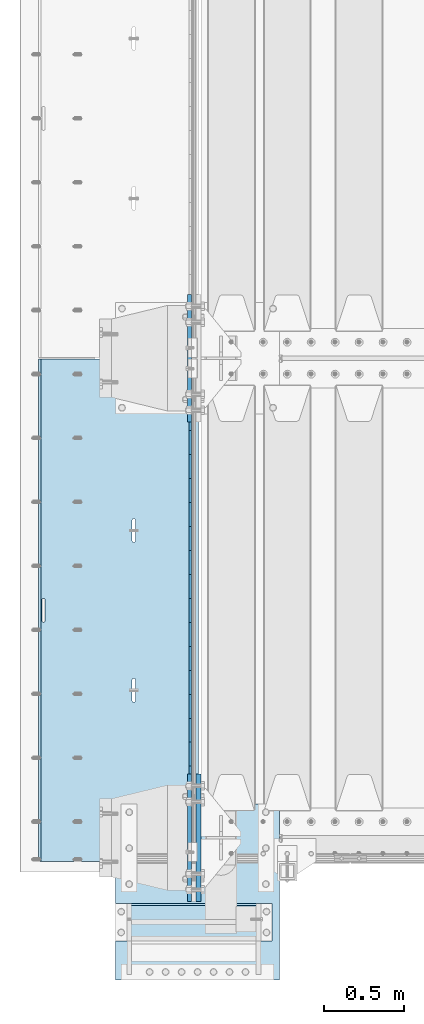
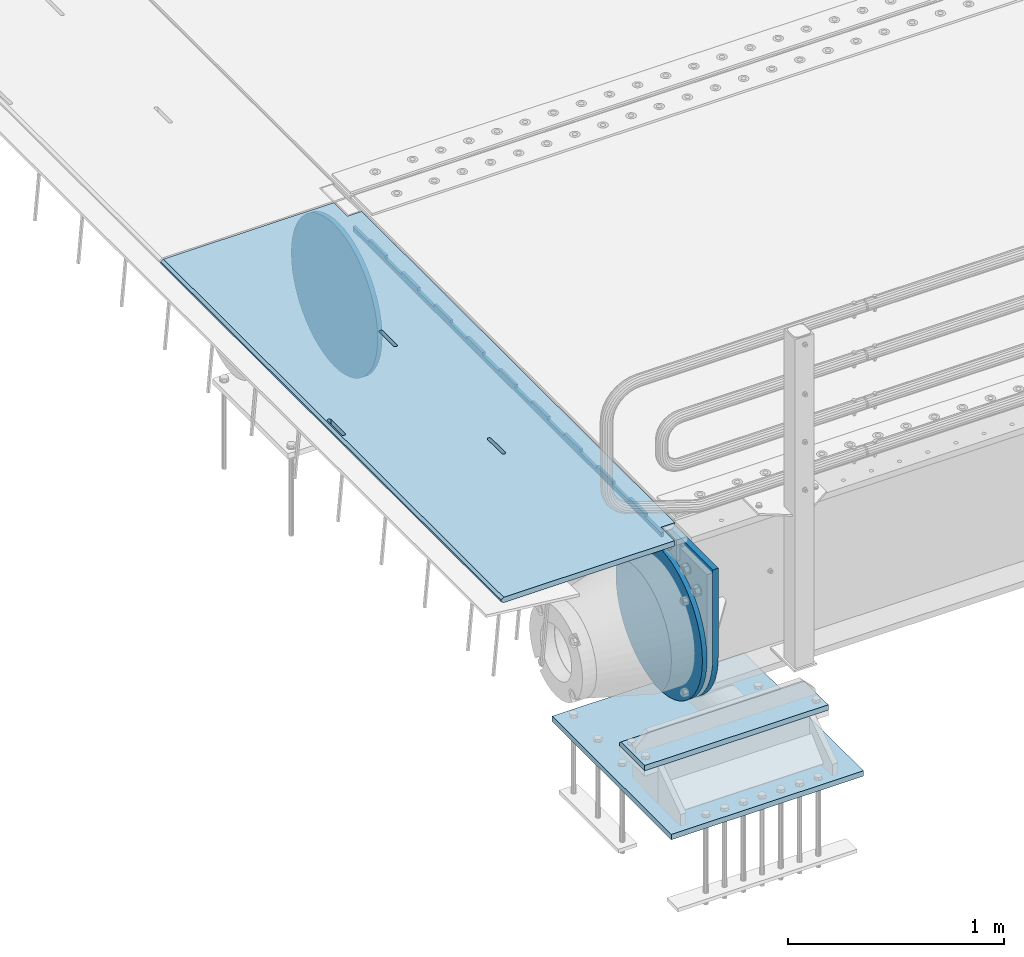
# One storey, part 208 of 270: 7 plates.
"""IFC2X3 building model written with IfcOpenShell, lengths in millimetres."""

import ifcopenshell
import ifcopenshell.guid

model = None  # the IFC model being written
_history = None  # IfcOwnerHistory: only IFC2X3 demands one
_inside = {}  # id of a spatial element -> (the spatial element, [elements in it])
_under = {}  # id of a project, library or spatial element -> (it, [spatial elements below it])
_declared = {}  # id of a project -> (the project, [libraries it declares])
_typed = {}  # id of a type object -> (the type object, [elements of that type])
_made_of = {}  # id of a material, layer set ... -> (it, [elements and type objects made of it])


def new_model(schema):
    """Start an empty IFC model of exactly this schema.

    Asked for "IFC4X3", IfcOpenShell would pick the latest addendum, in which some entities
    have other attributes; the version numbers below select the first issue.
    IFC2X3 requires an IfcOwnerHistory on every rooted entity: one is made here for all.
    """
    global model, _history
    if schema == "IFC4X3":
        model = ifcopenshell.file(schema_version=(4, 3, 0, 0))
    else:
        model = ifcopenshell.file(schema=schema)
    _inside.clear()
    _under.clear()
    _declared.clear()
    _typed.clear()
    _made_of.clear()
    _history = None
    if model.schema == "IFC2X3":
        org = make("IfcOrganization", Name="unknown")
        user = make(
            "IfcPersonAndOrganization",
            ThePerson=make("IfcPerson", FamilyName="unknown"),
            TheOrganization=org,
        )
        app = make(
            "IfcApplication",
            ApplicationDeveloper=org,
            Version="unknown",
            ApplicationFullName="unknown",
            ApplicationIdentifier="unknown",
        )
        _history = make(
            "IfcOwnerHistory",
            OwningUser=user,
            OwningApplication=app,
            ChangeAction="ADDED",
            CreationDate=0,
        )
    return model


def make(cls, **values):
    """One entity of the class cls with the attributes given. An attribute that is None is left unset."""
    return model.create_entity(
        cls, **{name: value for name, value in values.items() if value is not None}
    )


def rooted(cls, **values):
    """An entity with a GlobalId (a new one), such as an element, a storey or a relation."""
    return make(cls, GlobalId=ifcopenshell.guid.new(), OwnerHistory=_history, **values)


def si_unit(unit_type, name, prefix=None):
    """IfcSIUnit, for example si_unit("LENGTHUNIT", "METRE", prefix="MILLI")."""
    return make("IfcSIUnit", UnitType=unit_type, Prefix=prefix, Name=name)


def assignment(units):
    """IfcUnitAssignment: the units of a project."""
    return None if units is None else make("IfcUnitAssignment", Units=units)


def point(xyz):
    """IfcCartesianPoint."""
    return None if xyz is None else make("IfcCartesianPoint", Coordinates=xyz)


def direction(xyz):
    """IfcDirection."""
    return None if xyz is None else make("IfcDirection", DirectionRatios=xyz)


def frame(location, z_axis=None, x_axis=None):
    """IfcAxis2Placement3D, a coordinate frame: its origin and axes. An axis left out is left unset."""
    return make(
        "IfcAxis2Placement3D",
        Location=point(location),
        Axis=direction(z_axis),
        RefDirection=direction(x_axis),
    )


def origin_with_axes():
    """The frame at (0, 0, 0) with the z axis (0, 0, 1) and the x axis (1, 0, 0) written out."""
    return frame((0.0, 0.0, 0.0), z_axis=(0.0, 0.0, 1.0), x_axis=(1.0, 0.0, 0.0))


def place(relative_to, where):
    """IfcLocalPlacement: puts the frame where relative to a parent placement (None: the world)."""
    return make(
        "IfcLocalPlacement", PlacementRelTo=relative_to, RelativePlacement=where
    )


def context(
    kind, dimensions, precision=None, world=None, true_north=None, identifier=None
):
    """IfcGeometricRepresentationContext, for example the 3D "Model" context."""
    return make(
        "IfcGeometricRepresentationContext",
        ContextIdentifier=identifier,
        ContextType=kind,
        CoordinateSpaceDimension=dimensions,
        Precision=precision,
        WorldCoordinateSystem=world,
        TrueNorth=true_north,
    )


def subcontext(parent, identifier, kind, view, scale=None):
    """IfcGeometricRepresentationSubContext, for example "Body" below "Model"."""
    return make(
        "IfcGeometricRepresentationSubContext",
        ContextIdentifier=identifier,
        ContextType=kind,
        ParentContext=parent,
        TargetScale=scale,
        TargetView=view,
    )


def project(units=None, contexts=None):
    """IfcProject with its units and contexts."""
    return rooted(
        "IfcProject",
        Name="project",
        RepresentationContexts=contexts,
        UnitsInContext=assignment(units),
    )


def spatial(cls, under=None, at=None, **own):
    """A site, building, storey or space (cls), placed at a placement, below another one or the project."""
    s = rooted(cls, ObjectPlacement=at, **own)
    if under is not None:
        _under.setdefault(under.id(), (under, []))[1].append(s)
    return s


def faces_of(points, faces, orient=None, outer=None):
    """IfcFace entities. A face is a list of loops; a loop is a list of indices into points, from 0.

    orient and outer hold one flag for each loop. By default every Orientation is true, the
    first loop of a face is its IfcFaceOuterBound and the others are IfcFaceBound.
    """
    made = []
    for i, loops in enumerate(faces):
        bounds = []
        for j, loop in enumerate(loops):
            is_outer = j == 0 if outer is None else outer[i][j]
            bounds.append(
                make(
                    "IfcFaceOuterBound" if is_outer else "IfcFaceBound",
                    Bound=make("IfcPolyLoop", Polygon=[points[k] for k in loop]),
                    Orientation=True if orient is None else orient[i][j],
                )
            )
        made.append(make("IfcFace", Bounds=bounds))
    return made


def faceted_brep(points, faces, orient=None, outer=None, voids=None):
    """IfcFacetedBrep: a solid bounded by flat faces; with voids (closed shells), ...WithVoids."""
    shared = [point(p) for p in points]
    hull = make("IfcClosedShell", CfsFaces=faces_of(shared, faces, orient, outer))
    if voids is None:
        return make("IfcFacetedBrep", Outer=hull)
    return make(
        "IfcFacetedBrepWithVoids",
        Outer=hull,
        Voids=[
            make(cls, CfsFaces=faces_of(shared, fs, o, b)) for cls, fs, o, b in voids
        ],
    )


def shape(context_of_items, identifier, shape_type, items):
    """IfcShapeRepresentation: the items that make up one representation, for example the "Body"."""
    return make(
        "IfcShapeRepresentation",
        ContextOfItems=context_of_items,
        RepresentationIdentifier=identifier,
        RepresentationType=shape_type,
        Items=items,
    )


def material(Name=None, Category=None):
    """IfcMaterial."""
    return make("IfcMaterial", Name=Name, Category=Category)


def made_of(thing, what):
    """Note that an element or type object is made of a material, layer set ...; save() writes the relation."""
    if what is not None:
        _made_of.setdefault(what.id(), (what, []))[1].append(thing)
    return thing


def type_object(cls, material=None, **own):
    """A type object (cls), such as IfcWallType, which elements share."""
    return made_of(rooted(cls, **own), material)


def element(
    cls,
    number,
    at=None,
    inside=None,
    cuts=None,
    type_object=None,
    material=None,
    context=None,
    identifier="Body",
    shape_type=None,
    held_by="IfcProductDefinitionShape",
    body=None,
    shapes=None,
    **own,
):
    """One element of the class cls, such as IfcWall. Its Tag is "e" and its number.

    at: its placement. inside: the storey or other place that contains it. cuts: it is an
    opening in that element (IfcRelVoidsElement). A single representation is given by context,
    identifier, shape_type and body (its items); several are given by shapes. held_by: the class
    of the entity that holds the representations. save() writes the other relations.
    """
    e = rooted(cls, Tag="e%d" % number, ObjectPlacement=at, **own)
    if body is not None:
        shapes = [shape(context, identifier, shape_type, body)]
    if shapes is not None:
        e.Representation = make(held_by, Representations=shapes)
    if inside is not None:
        _inside.setdefault(inside.id(), (inside, []))[1].append(e)
    if cuts is not None:
        rooted(
            "IfcRelVoidsElement", RelatingBuildingElement=cuts, RelatedOpeningElement=e
        )
    if type_object is not None:
        _typed.setdefault(type_object.id(), (type_object, []))[1].append(e)
    return made_of(e, material)


def aggregate(whole, parts):
    """IfcRelAggregates: a whole, such as a stair, and the parts it consists of."""
    return rooted("IfcRelAggregates", RelatingObject=whole, RelatedObjects=parts)


def save(model, path):
    """Write the relations noted so far, then the file.

    IfcRelAggregates (storeys below a building ...), IfcRelContainedInSpatialStructure (elements
    in a storey), IfcRelDefinesByType, IfcRelAssociatesMaterial and IfcRelDeclares: one each for
    every whole, place, type object, material and project.
    """
    for whole, parts in _under.values():
        aggregate(whole, parts)
    for where, things in _inside.values():
        rooted(
            "IfcRelContainedInSpatialStructure",
            RelatedElements=things,
            RelatingStructure=where,
        )
    for kind, things in _typed.values():
        rooted("IfcRelDefinesByType", RelatedObjects=things, RelatingType=kind)
    for what, things in _made_of.values():
        rooted("IfcRelAssociatesMaterial", RelatedObjects=things, RelatingMaterial=what)
    for by, libraries in _declared.values():
        rooted("IfcRelDeclares", RelatingContext=by, RelatedDefinitions=libraries)
    model.write(path)


model = new_model("IFC2X3")

# Units and contexts
model_context = context("Model", 3, precision=1e-05, world=origin_with_axes())
body_context = subcontext(model_context, "Body", "Model", "MODEL_VIEW")
ifc_project = project(units=[si_unit("LENGTHUNIT", "METRE", prefix="MILLI"), si_unit("AREAUNIT", "SQUARE_METRE"), si_unit("VOLUMEUNIT", "CUBIC_METRE"), si_unit("MASSUNIT", "GRAM", prefix="KILO"), si_unit("TIMEUNIT", "SECOND"), si_unit("PLANEANGLEUNIT", "RADIAN"), si_unit("SOLIDANGLEUNIT", "STERADIAN"), si_unit("THERMODYNAMICTEMPERATUREUNIT", "DEGREE_CELSIUS"), si_unit("LUMINOUSINTENSITYUNIT", "LUMEN")], contexts=[model_context])

# Site, building, storey
site_placement = place(None, origin_with_axes())
site = spatial("IfcSite", under=ifc_project, at=site_placement, CompositionType="ELEMENT")
building_placement = place(site_placement, origin_with_axes())
building = spatial("IfcBuilding", under=site, at=building_placement, Name="Standard", CompositionType="ELEMENT")
storey_placement = place(building_placement, origin_with_axes())
storey = spatial("IfcBuildingStorey", under=building, at=storey_placement, Name="Undefined", CompositionType="ELEMENT", Elevation=0.0)

# Plates
ifc_material_1 = material(Name="STEEL/S355N")
plate_type_1 = type_object("IfcPlateType", PredefinedType="NOTDEFINED")
plate_1_placement = place(storey_placement, frame((-57.5000000000039, -21152.4999006275, -35.9858217365063), z_axis=(0.0, -0.999999999987744, -4.95099999993769e-06), x_axis=(0.0, 4.95100000930963e-06, -0.999999999987744)))
element("IfcPlate", 1, at=plate_1_placement, inside=storey, type_object=plate_type_1, material=ifc_material_1, context=body_context, shape_type="Brep", body=[
    faceted_brep([(-7.105427357601e-15, -7.49999999999999, 0.0), (8.68283223098842e-12, -7.49999999999999, 150.000000000004), (8.68283223098842e-12, 7.5, 150.000000000004), (-7.105427357601e-15, 7.5, 0.0), (-14.9999999999986, -7.49999999999999, 150.0), (-14.9999999999986, 7.5, 150.0), (-14.9999999999972, -7.49999999999999, 300.0), (-14.9999999999972, 7.5, 300.0), (1.55324642037158e-11, -7.49999999999999, 300.0), (1.55324642037158e-11, 7.5, 300.0), (1.87654336514242e-11, -7.49999999999999, 450.0), (1.87654336514242e-11, 7.5, 450.0), (-14.9999999999958, -7.49999999999999, 450.0), (-14.9999999999958, 7.5, 450.0), (-14.9999999999944, -7.49999999999999, 600.0), (-14.9999999999944, 7.5, 600.0), (2.74411604550551e-11, -7.49999999999999, 600.000000000004), (2.74411604550551e-11, 7.5, 600.000000000004), (3.24860138789518e-11, -7.49999999999999, 750.0), (3.24860138789518e-11, 7.5, 750.0), (-14.999999999993, -7.49999999999999, 750.0), (-14.999999999993, 7.5, 750.0), (-14.9999999999916, -7.49999999999999, 900.000000000004), (-14.9999999999916, 7.5, 900.000000000004), (4.11688461099402e-11, -7.49999999999999, 900.0), (4.11688461099402e-11, 7.5, 900.0), (4.62136995338369e-11, -7.49999999999999, 1050.0), (4.62136995338369e-11, 7.5, 1050.0), (-14.9999999999902, -7.49999999999999, 1050.0), (-14.9999999999902, 7.5, 1050.0), (-14.9999999999888, -7.49999999999999, 1200.0), (-14.9999999999888, 7.5, 1200.0), (5.30775423612795e-11, -7.49999999999999, 1200.0), (5.30775423612795e-11, 7.5, 1200.0), (5.99413851887221e-11, -7.49999999999999, 1350.0), (5.99413851887221e-11, 7.5, 1350.0), (-14.9999999999874, -7.49999999999999, 1350.0), (-14.9999999999874, 7.5, 1350.0), (-14.9999999999859, -7.49999999999999, 1500.0), (-14.9999999999859, 7.5, 1500.0), (6.49862386126188e-11, -7.49999999999999, 1500.0), (6.49862386126188e-11, 7.5, 1500.0), (7.36690708436072e-11, -7.49999999999999, 1650.0), (7.36690708436072e-11, 7.5, 1650.0), (-14.9999999999845, -7.49999999999999, 1650.0), (-14.9999999999845, 7.5, 1650.0), (-14.9999999999831, -7.49999999999999, 1800.0), (-14.9999999999831, 7.5, 1800.0), (7.68878294366004e-11, -7.49999999999999, 1800.0), (7.68878294366004e-11, 7.5, 1800.0), (8.3751672264043e-11, -7.49999999999999, 1950.0), (8.3751672264043e-11, 7.5, 1950.0), (-14.9999999999817, -7.49999999999999, 1950.0), (-14.9999999999817, 7.5, 1950.0), (-14.9999999999803, -7.49999999999999, 2100.0), (-14.9999999999803, 7.5, 2100.0), (9.06226205188432e-11, -7.49999999999999, 2100.0), (9.06226205188432e-11, 7.5, 2100.0), (9.56603685153823e-11, -7.49999999999999, 2250.0), (9.56603685153823e-11, 7.5, 2250.0), (-14.9999999999789, -7.49999999999999, 2250.0), (-14.9999999999789, 7.5, 2250.0), (-14.9999999999775, -7.49999999999999, 2400.0), (-14.9999999999775, 7.5, 2400.0), (1.04343200746371e-10, -7.49999999999999, 2400.0), (1.04343200746371e-10, 7.5, 2400.0), (1.0938094874291e-10, -7.49999999999999, 2550.0), (1.0938094874291e-10, 7.5, 2550.0), (-14.9999999999761, -7.49999999999999, 2550.0), (-14.9999999999761, 7.5, 2550.0), (-14.9999999999747, -7.49999999999999, 2700.0), (-14.9999999999747, 7.5, 2700.0), (1.14432907594164e-10, -7.49999999999999, 2700.0), (1.14432907594164e-10, 7.5, 2700.0), (1.23108634397795e-10, -7.49999999999999, 2850.0), (1.23108634397795e-10, 7.5, 2850.0), (25.0000000000267, -7.49999999999999, 2850.0), (25.0000000000267, 7.5, 2850.0), (25.0, -7.49999999999999, 0.0), (25.0, 7.5, 0.0)], [[[0, 1, 2, 3]], [[1, 4, 5, 2]], [[4, 6, 7, 5]], [[6, 8, 9, 7]], [[8, 10, 11, 9]], [[10, 12, 13, 11]], [[12, 14, 15, 13]], [[14, 16, 17, 15]], [[16, 18, 19, 17]], [[18, 20, 21, 19]], [[20, 22, 23, 21]], [[22, 24, 25, 23]], [[24, 26, 27, 25]], [[26, 28, 29, 27]], [[28, 30, 31, 29]], [[30, 32, 33, 31]], [[32, 34, 35, 33]], [[34, 36, 37, 35]], [[36, 38, 39, 37]], [[38, 40, 41, 39]], [[40, 42, 43, 41]], [[42, 44, 45, 43]], [[44, 46, 47, 45]], [[46, 48, 49, 47]], [[48, 50, 51, 49]], [[50, 52, 53, 51]], [[52, 54, 55, 53]], [[54, 56, 57, 55]], [[56, 58, 59, 57]], [[58, 60, 61, 59]], [[60, 62, 63, 61]], [[62, 64, 65, 63]], [[64, 66, 67, 65]], [[66, 68, 69, 67]], [[68, 70, 71, 69]], [[70, 72, 73, 71]], [[72, 74, 75, 73]], [[74, 76, 77, 75]], [[76, 78, 79, 77]], [[78, 0, 3, 79]], [[5, 7, 9, 11, 13, 15, 17, 19, 21, 23, 25, 27, 29, 31, 33, 35, 37, 39, 41, 43, 45, 47, 49, 51, 53, 55, 57, 59, 61, 63, 65, 67, 69, 71, 73, 75, 77, 79, 3, 2]], [[78, 76, 74, 72, 70, 68, 66, 64, 62, 60, 58, 56, 54, 52, 50, 48, 46, 44, 42, 40, 38, 36, 34, 32, 30, 28, 26, 24, 22, 20, 18, 16, 14, 12, 10, 8, 6, 4, 1, 0]]]),
])
plate_type_2 = type_object("IfcPlateType", PredefinedType="NOTDEFINED")
plate_2_placement = place(storey_placement, frame((-5.00375457088524, -21005.0000738707, -0.984429074950507), z_axis=(0.0, -0.999999999987744, -4.95099999993769e-06), x_axis=(-0.999999999879068, -1.00000022172504e-09, -1.55519999981193e-05)))
element("IfcPlate", 2, at=plate_2_placement, inside=storey, type_object=plate_type_2, material=ifc_material_1, context=body_context, shape_type="Brep", body=[
    faceted_brep([(14.9998601691701, 15.0, 125.000024820878), (-0.000294611402146039, -0.000806902969057388, 124.999936248681), (-0.00191941583158783, 0.000806844427335363, 3020.00000492307), (14.9966216875132, 15.0, 3020.00007976655), (999.996459960937, 5.0, 3.63797880709171e-12), (984.996459960937, 15.0, 3.63797880709171e-12), (984.996459718778, 15.0, 3145.0), (999.996459718778, 5.0, 3145.0), (984.996459961366, -15.0, 0.0), (999.996459960937, -5.0, 3.63797880709171e-12), (999.996459718778, -5.0, 3145.0), (984.996459719206, -15.0, 3145.0), (74.9997820614451, -15.0, 0.0), (74.9996421865538, -15.0000000127077, 124.999930084148), (75.0001087165527, 15.0, 125.000079754147), (75.0002485914438, 15.0, 0.0), (-0.000449375328801516, -14.9999999951864, 124.999861417793), (960.486056642586, -14.9999999941054, 1504.40983005418), (960.486056642586, 15.0, 1504.40983005418), (959.996621805299, 15.0, 1507.49999999792), (959.996621805299, -14.9999999941178, 1507.49999999793), (961.906451862003, -14.9999999940729, 1501.622147475), (961.906451862003, 15.0, 1501.622147475), (964.118769282998, -14.9999999940233, 1499.40983005418), (964.118769282998, 15.0, 1499.40983005418), (966.906451862283, -14.9999999939616, 1497.98943483498), (966.906451862283, 15.0, 1497.98943483497), (969.99662180607, -14.9999999938938, 1497.49999999793), (969.99662180607, 15.0, 1497.49999999793), (973.086791749665, -14.9999999938266, 1497.98943483497), (973.086791749666, 15.0, 1497.98943483497), (975.87447432873, -14.9999999937664, 1499.40983005418), (975.87447432873, 15.0, 1499.40983005418), (978.086791749384, -14.9999999937193, 1501.622147475), (978.086791749384, 15.0, 1501.622147475), (979.507186968372, -14.9999999936897, 1504.40983005417), (979.507186968372, 15.0, 1504.40983005417), (979.996621805185, -14.9999999936807, 1507.49999999792), (979.996621805184, 15.0, 1507.49999999792), (979.996621795271, -14.9999999937513, 1637.49999999792), (979.996621795271, 15.0, 1637.49999999792), (979.507186957986, -14.9999999937636, 1640.59016994167), (979.507186957986, 15.0, 1640.59016994167), (978.08679173857, -14.9999999937962, 1643.37785252085), (978.08679173857, 15.0, 1643.37785252085), (975.874474317574, -14.9999999938457, 1645.59016994168), (975.874474317574, 15.0, 1645.59016994168), (973.086791738289, -14.9999999939074, 1647.01056516088), (973.086791738289, 15.0, 1647.01056516088), (969.9966217945, -14.9999999939752, 1647.49999999793), (969.9966217945, 15.0, 1647.49999999793), (966.906451850796, -14.9999999940425, 1647.01056516088), (966.906451850796, 15.0, 1647.01056516088), (964.118769271731, -14.9999999941026, 1645.59016994168), (964.118769271731, 15.0, 1645.59016994168), (961.906451851076, -14.9999999941498, 1643.37785252085), (961.906451851077, 15.0, 1643.37785252085), (960.486056632089, -14.9999999941793, 1640.59016994168), (960.486056632089, 15.0, 1640.59016994168), (959.996621795279, -14.9999999941883, 1637.49999999793), (959.996621795279, 15.0, 1637.49999999792), (395.486056681079, -15.0000000061812, 1004.40983005448), (395.486056681079, 15.0, 1004.40983005447), (394.996621843792, 15.0, 1007.49999999822), (394.996621843792, -15.0000000061936, 1007.49999999823), (396.906451900496, -15.0000000061487, 1001.6221474753), (396.906451900496, 15.0, 1001.6221474753), (399.118769321491, -15.0000000060991, 999.409830054472), (399.118769321491, 15.0, 999.409830054472), (401.906451900776, -15.0000000060374, 997.989434835275), (401.906451900776, 15.0, 997.989434835272), (404.996621844563, -15.0000000059696, 997.499999998225), (404.996621844563, 15.0, 997.499999998221), (408.086791788159, -15.0000000059024, 997.989434835272), (408.086791788159, 15.0, 997.989434835272), (410.874474367224, -15.0000000058422, 999.409830054472), (410.874474367224, 15.0, 999.409830054472), (413.086791787878, -15.0000000057951, 1001.6221474753), (413.086791787877, 15.0, 1001.62214747529), (414.507187006866, -15.0000000057655, 1004.40983005447), (414.507187006866, 15.0, 1004.40983005447), (414.996621843678, -15.0000000057565, 1007.49999999822), (414.996621843678, 15.0, 1007.49999999821), (414.996621833764, -15.0000000058271, 1137.49999999822), (414.996621833764, 15.0, 1137.49999999821), (414.507186996479, -15.0000000058394, 1140.59016994197), (414.507186996479, 15.0, 1140.59016994197), (413.086791777063, -15.000000005872, 1143.37785252115), (413.086791777063, 15.0, 1143.37785252114), (410.874474356068, -15.0000000059215, 1145.59016994197), (410.874474356068, 15.0, 1145.59016994197), (408.086791776782, -15.0000000059832, 1147.01056516118), (408.086791776782, 15.0, 1147.01056516118), (404.996621832993, -15.000000006051, 1147.49999999822), (404.996621832993, 15.0, 1147.49999999822), (401.90645188929, -15.0000000061183, 1147.01056516118), (401.90645188929, 15.0, 1147.01056516117), (399.118769310224, -15.0000000061784, 1145.59016994197), (399.118769310224, 15.0, 1145.59016994197), (396.90645188957, -15.0000000062256, 1143.37785252115), (396.90645188957, 15.0, 1143.37785252115), (395.486056670583, -15.0000000062551, 1140.59016994197), (395.486056670583, 15.0, 1140.59016994197), (394.996621833772, -15.0000000062641, 1137.49999999822), (394.996621833772, 15.0, 1137.49999999822), (74.9967306508662, 15.0, 3145.0), (74.9962640908673, -15.0, 3145.0), (74.9968705257564, 15.0, 3020.00007982415), (74.9964039657577, -15.0, 3019.99993015415), (-0.000460362207132192, -15.00000004538, 3019.99993008594), (395.486056593588, -15.0000000067978, 2140.59016994145), (396.906451812575, -15.0000000067683, 2143.37785252062), (399.118769233229, -15.0000000067211, 2145.59016994145), (401.906451812295, -15.000000006661, 2147.01056516065), (404.996621755999, -15.0000000065937, 2147.49999999769), (408.086791699787, -15.0000000065259, 2147.01056516065), (410.874474279073, -15.0000000064642, 2145.59016994145), (413.086791700069, -15.0000000064147, 2143.37785252062), (414.507186919485, -15.0000000063821, 2140.59016994144), (414.99662175677, -15.0000000063698, 2137.49999999769), (414.996621766684, -15.0000000062992, 2007.49999999769), (414.507186929871, -15.0000000063082, 2004.40983005394), (413.086791710883, -15.0000000063378, 2001.62214747477), (410.874474290229, -15.0000000063849, 1999.40983005394), (408.086791711164, -15.0000000064451, 1997.98943483474), (404.996621767569, -15.0000000065123, 1997.4999999977), (401.906451823781, -15.0000000065801, 1997.98943483475), (399.118769244497, -15.0000000066418, 1999.40983005394), (396.906451823501, -15.0000000066914, 2001.62214747477), (395.486056604085, -15.0000000067239, 2004.40983005394), (394.996621766798, -15.0000000067363, 2007.4999999977), (394.996621756778, -15.0000000068068, 2137.4999999977), (396.906451823501, 15.0, 2001.62214747477), (395.486056604084, 15.0, 2004.40983005394), (399.118769244497, 15.0, 1999.40983005394), (401.906451823781, 15.0, 1997.98943483474), (404.996621767569, 15.0, 1997.49999999769), (408.086791711164, 15.0, 1997.98943483474), (410.874474290229, 15.0, 1999.40983005394), (413.086791710883, 15.0, 2001.62214747477), (414.507186929871, 15.0, 2004.40983005394), (414.996621766684, 15.0, 2007.49999999769), (414.99662175677, 15.0, 2137.49999999769), (414.507186919485, 15.0, 2140.59016994144), (413.086791700069, 15.0, 2143.37785252061), (410.874474279073, 15.0, 2145.59016994144), (408.086791699787, 15.0, 2147.01056516065), (404.996621755999, 15.0, 2147.49999999769), (401.906451812295, 15.0, 2147.01056516065), (399.118769233229, 15.0, 2145.59016994145), (396.906451812575, 15.0, 2143.37785252062), (395.486056593588, 15.0, 2140.59016994144), (394.996621756778, 15.0, 2137.4999999977), (394.996621766798, 15.0, 2007.4999999977)], [[[0, 1, 2, 3]], [[4, 5, 6, 7]], [[8, 9, 10, 11]], [[12, 13, 14, 15]], [[14, 13, 16, 1, 0]], [[17, 18, 19, 20]], [[21, 22, 18, 17]], [[23, 24, 22, 21]], [[25, 26, 24, 23]], [[27, 28, 26, 25]], [[29, 30, 28, 27]], [[31, 32, 30, 29]], [[33, 34, 32, 31]], [[35, 36, 34, 33]], [[37, 38, 36, 35]], [[39, 40, 38, 37]], [[41, 42, 40, 39]], [[43, 44, 42, 41]], [[45, 46, 44, 43]], [[47, 48, 46, 45]], [[49, 50, 48, 47]], [[51, 52, 50, 49]], [[53, 54, 52, 51]], [[55, 56, 54, 53]], [[57, 58, 56, 55]], [[59, 60, 58, 57]], [[20, 19, 60, 59]], [[61, 62, 63, 64]], [[65, 66, 62, 61]], [[67, 68, 66, 65]], [[69, 70, 68, 67]], [[71, 72, 70, 69]], [[73, 74, 72, 71]], [[75, 76, 74, 73]], [[77, 78, 76, 75]], [[79, 80, 78, 77]], [[81, 82, 80, 79]], [[83, 84, 82, 81]], [[85, 86, 84, 83]], [[87, 88, 86, 85]], [[89, 90, 88, 87]], [[91, 92, 90, 89]], [[93, 94, 92, 91]], [[95, 96, 94, 93]], [[97, 98, 96, 95]], [[99, 100, 98, 97]], [[101, 102, 100, 99]], [[103, 104, 102, 101]], [[64, 63, 104, 103]], [[9, 8, 12, 15, 5, 4]], [[10, 9, 4, 7]], [[105, 106, 11, 10, 7, 6]], [[106, 105, 107, 108]], [[109, 108, 107, 3, 2]], [[106, 108, 109, 16, 13, 12, 8, 11], [101, 99, 97, 95, 93, 91, 89, 87, 85, 83, 81, 79, 77, 75, 73, 71, 69, 67, 65, 61, 64, 103], [57, 55, 53, 51, 49, 47, 45, 43, 41, 39, 37, 35, 33, 31, 29, 27, 25, 23, 21, 17, 20, 59], [110, 111, 112, 113, 114, 115, 116, 117, 118, 119, 120, 121, 122, 123, 124, 125, 126, 127, 128, 129, 130, 131]], [[128, 132, 133, 129]], [[127, 134, 132, 128]], [[126, 135, 134, 127]], [[125, 136, 135, 126]], [[124, 137, 136, 125]], [[123, 138, 137, 124]], [[122, 139, 138, 123]], [[121, 140, 139, 122]], [[120, 141, 140, 121]], [[119, 142, 141, 120]], [[118, 143, 142, 119]], [[117, 144, 143, 118]], [[116, 145, 144, 117]], [[115, 146, 145, 116]], [[114, 147, 146, 115]], [[113, 148, 147, 114]], [[112, 149, 148, 113]], [[111, 150, 149, 112]], [[110, 151, 150, 111]], [[131, 152, 151, 110]], [[130, 153, 152, 131]], [[129, 133, 153, 130]], [[107, 105, 6, 5, 15, 14, 0, 3], [132, 134, 135, 136, 137, 138, 139, 140, 141, 142, 143, 144, 145, 146, 147, 148, 149, 150, 151, 152, 153, 133], [22, 24, 26, 28, 30, 32, 34, 36, 38, 40, 42, 44, 46, 48, 50, 52, 54, 56, 58, 60, 19, 18], [66, 68, 70, 72, 74, 76, 78, 80, 82, 84, 86, 88, 90, 92, 94, 96, 98, 100, 102, 104, 63, 62]], [[16, 109, 2, 1]]]),
])
ifc_material_2 = material()
plate_type_3 = type_object("IfcPlateType", PredefinedType="NOTDEFINED")
plate_3_placement = place(storey_placement, frame((455.000000735005, -24645.000002937, -813.000000000004), z_axis=(0.0, 1.0, 0.0), x_axis=(-1.0, 0.0, 0.0)))
element("IfcPlate", 3, at=plate_3_placement, inside=storey, type_object=plate_type_3, material=ifc_material_2, context=body_context, shape_type="Brep", body=[
    faceted_brep([(979.0, 0.0, 235.0), (979.0, 15.0, 220.0), (3.41060513164848e-13, 15.0, 220.0), (0.0, 0.0, 235.0), (0.0, 15.0, 0.0), (0.0, -15.0, 0.0), (3.41060513164848e-13, -15.0, 235.0), (979.0, -15.0, 235.0), (979.0, -15.0, 0.0), (979.0, 15.0, 0.0)], [[[0, 1, 2, 3]], [[4, 5, 6, 3, 2]], [[6, 7, 0, 3]], [[7, 8, 9, 1, 0]], [[8, 5, 4, 9]], [[9, 4, 2, 1]], [[8, 7, 6, 5]]]),
])
plate_type_4 = type_object("IfcPlateType", PredefinedType="NOTDEFINED")
plate_4_placement = place(storey_placement, frame((-523.999999999989, -24890.0, -1053.0), z_axis=(1.0, 0.0, 0.0), x_axis=(0.0, 1.0, 0.0)))
element("IfcPlate", 4, at=plate_4_placement, inside=storey, type_object=plate_type_4, material=ifc_material_2, context=body_context, shape_type="Brep", body=[
    faceted_brep([(0.0, -15.0, 0.0), (2.93249286187347e-06, -15.0, 1025.0), (2.93249286187347e-06, 15.0, 1025.0), (0.0, 15.0, 0.0), (1100.0, -15.0, 1025.0), (1100.0, 15.0, 1025.0), (1100.0, -15.0, -1.9554136088118e-11), (1100.0, 15.0, -1.9554136088118e-11)], [[[0, 1, 2, 3]], [[1, 4, 5, 2]], [[4, 6, 7, 5]], [[6, 0, 3, 7]], [[5, 7, 3, 2]], [[6, 4, 1, 0]]]),
])
plate_type_5 = type_object("IfcPlateType", PredefinedType="NOTDEFINED")
plate_5_placement = place(storey_placement, frame((-5.0, -24400.0, -20.0), z_axis=(0.0, 1.0, 0.0), x_axis=(0.0, 0.0, -1.0)))
element("IfcPlate", 5, at=plate_5_placement, inside=storey, type_object=plate_type_5, material=ifc_material_1, context=body_context, shape_type="Brep", body=[
    faceted_brep([(855.0, -15.0, 572.963114671544), (855.0, 15.0, 572.963114671544), (849.182410261294, 15.0, 585.889268817533), (849.182410261294, -15.0, 585.889268817533), (824.193546357474, 15.0, 627.225898692486), (824.193546357474, -15.0, 627.225898692486), (794.404299268454, 15.0, 665.249063296342), (794.404299268454, -15.0, 665.249063296342), (760.249063296334, 15.0, 699.404299268463), (760.249063296334, -15.0, 699.404299268463), (722.22589869248, 15.0, 729.193546357488), (722.22589869248, -15.0, 729.193546357488), (680.889268817528, 15.0, 754.18241026131), (680.889268817528, -15.0, 754.18241026131), (636.841954817037, 15.0, 774.006497074191), (636.841954817037, -15.0, 774.006497074191), (590.726265715048, 15.0, 788.376726970451), (590.726265715048, -15.0, 788.376726970451), (543.214672102156, 15.0, 797.083549639254), (543.214672102156, -15.0, 797.083549639254), (495.0, -15.0, 800.000000000029), (495.0, 15.0, 800.0), (494.999999999412, -15.0, 0.0), (494.999999999412, 15.0, 0.0), (543.214672102129, 15.0, 2.91645036080809), (543.214672102129, -15.0, 2.91645036080809), (590.726265715023, 15.0, 11.6232730296069), (590.726265715023, -15.0, 11.6232730296069), (636.841954817014, 15.0, 25.9935029258631), (636.841954817014, -15.0, 25.9935029258631), (680.889268817507, 15.0, 45.8175897387446), (680.889268817507, -15.0, 45.8175897387446), (722.225898692462, 15.0, 70.8064536425663), (722.225898692462, -15.0, 70.8064536425663), (760.249063296318, 15.0, 100.595700731588), (760.249063296318, -15.0, 100.595700731588), (794.404299268441, 15.0, 134.750936703713), (794.404299268441, -15.0, 134.750936703713), (824.193546357463, 15.0, 172.774101307568), (824.193546357463, -15.0, 172.774101307568), (849.182410261284, 15.0, 214.110731182522), (849.182410261284, -15.0, 214.110731182522), (855.0, -15.0, 227.036885328536), (855.0, 15.0, 227.036885328536), (0.0, -15.0, 0.0), (0.0, 15.0, 0.0), (0.0, 15.0, 800.0), (0.0, -15.0, 800.0)], [[[0, 1, 2, 3]], [[3, 2, 4, 5]], [[5, 4, 6, 7]], [[7, 6, 8, 9]], [[9, 8, 10, 11]], [[11, 10, 12, 13]], [[13, 12, 14, 15]], [[15, 14, 16, 17]], [[17, 16, 18, 19]], [[20, 19, 18, 21]], [[22, 23, 24, 25]], [[25, 24, 26, 27]], [[27, 26, 28, 29]], [[29, 28, 30, 31]], [[31, 30, 32, 33]], [[33, 32, 34, 35]], [[35, 34, 36, 37]], [[37, 36, 38, 39]], [[39, 38, 40, 41]], [[42, 41, 40, 43]], [[42, 43, 1, 0]], [[44, 45, 23, 22]], [[16, 14, 12, 10, 8, 6, 4, 2, 1, 43, 40, 38, 36, 34, 32, 30, 28, 26, 24, 23, 45, 46, 21, 18]], [[44, 47, 46, 45]], [[46, 47, 20, 21]], [[47, 44, 22, 25, 27, 29, 31, 33, 35, 37, 39, 41, 42, 0, 3, 5, 7, 9, 11, 13, 15, 17, 19, 20]]]),
])
plate_type_6 = type_object("IfcPlateType", PredefinedType="NOTDEFINED")
plate_6_placement = place(storey_placement, frame((-62.5000000000001, -20600.0, -114.999999999998), z_axis=(0.0, 0.0, -1.0), x_axis=(0.0, -1.0, 0.0)))
element("IfcPlate", 6, at=plate_6_placement, inside=storey, type_object=plate_type_6, material=ifc_material_1, context=body_context, shape_type="Brep", body=[
    faceted_brep([(0.0, -12.5, 400.0), (2.91645036077898, -12.5, 448.214672102129), (2.91645036077898, 12.5, 448.214672102129), (0.0, 12.5, 400.0), (11.6232730295797, -12.5, 495.726265715023), (11.6232730295797, 12.5, 495.726265715023), (25.993502925834, -12.5, 541.841954817014), (25.993502925834, 12.5, 541.841954817014), (45.8175897387155, -12.5, 585.889268817507), (45.8175897387155, 12.5, 585.889268817507), (70.8064536425372, -12.5, 627.225898692462), (70.8064536425372, 12.5, 627.225898692462), (100.595700731559, -12.5, 665.249063296318), (100.595700731559, 12.5, 665.249063296318), (134.750936703682, -12.5, 699.40429926844), (134.750936703682, 12.5, 699.40429926844), (172.774101307537, -12.5, 729.193546357462), (172.774101307537, 12.5, 729.193546357462), (214.110731182493, -12.5, 754.182410261284), (214.110731182493, 12.5, 754.182410261284), (258.158045182985, -12.5, 774.006497074166), (258.158045182985, 12.5, 774.006497074166), (304.273734284976, -12.5, 788.376726970421), (304.273734284976, 12.5, 788.376726970421), (351.785327897871, -12.5, 797.083549639221), (351.785327897871, 12.5, 797.083549639221), (400.0, -12.5, 800.0), (400.0, 12.5, 800.0), (448.214672102129, -12.5, 797.083549639222), (448.214672102129, 12.5, 797.083549639222), (495.726265715022, -12.5, 788.376726970421), (495.726265715022, 12.5, 788.376726970421), (541.841954817013, -12.5, 774.006497074166), (541.841954817013, 12.5, 774.006497074166), (585.889268817507, -12.5, 754.182410261284), (585.889268817507, 12.5, 754.182410261284), (627.225898692463, -12.5, 729.193546357463), (627.225898692463, 12.5, 729.193546357463), (665.249063296318, -12.5, 699.404299268441), (665.249063296318, 12.5, 699.404299268441), (699.404299268441, -12.5, 665.249063296318), (699.404299268441, 12.5, 665.249063296318), (729.193546357463, -12.5, 627.225898692462), (729.193546357463, 12.5, 627.225898692462), (754.182410261285, -12.5, 585.889268817507), (754.182410261285, 12.5, 585.889268817507), (774.006497074166, -12.5, 541.841954817014), (774.006497074166, 12.5, 541.841954817014), (788.37672697042, -12.5, 495.726265715023), (788.37672697042, 12.5, 495.726265715023), (797.083549639221, -12.5, 448.214672102129), (797.083549639221, 12.5, 448.214672102129), (800.0, -12.5, 400.0), (800.0, 12.5, 400.0), (797.083549639221, -12.5, 351.785327897871), (797.083549639221, 12.5, 351.785327897871), (788.37672697042, -12.5, 304.273734284977), (788.37672697042, 12.5, 304.273734284977), (774.006497074166, -12.5, 258.158045182986), (774.006497074166, 12.5, 258.158045182986), (754.182410261285, -12.5, 214.110731182493), (754.182410261285, 12.5, 214.110731182493), (729.193546357463, -12.5, 172.774101307538), (729.193546357463, 12.5, 172.774101307538), (699.404299268441, -12.5, 134.750936703682), (699.404299268441, 12.5, 134.750936703682), (665.249063296318, -12.5, 100.59570073156), (665.249063296318, 12.5, 100.59570073156), (627.225898692463, -12.5, 70.8064536425375), (627.225898692463, 12.5, 70.8064536425375), (585.889268817507, -12.5, 45.817589738716), (585.889268817507, 12.5, 45.817589738716), (541.841954817015, -12.5, 25.9935029258342), (541.841954817015, 12.5, 25.9935029258342), (495.726265715024, -12.5, 11.6232730295793), (495.726265715024, 12.5, 11.6232730295793), (448.214672102129, -12.5, 2.91645036077847), (448.214672102129, 12.5, 2.91645036077847), (400.0, -12.5, -5.6843418860808e-14), (400.0, 12.5, -5.6843418860808e-14), (351.785327897871, -12.5, 2.91645036077836), (351.785327897871, 12.5, 2.91645036077836), (304.273734284976, -12.5, 11.6232730295792), (304.273734284976, 12.5, 11.6232730295792), (258.158045182985, -12.5, 25.993502925834), (258.158045182985, 12.5, 25.993502925834), (214.110731182493, -12.5, 45.817589738716), (214.110731182493, 12.5, 45.817589738716), (172.774101307537, -12.5, 70.8064536425374), (172.774101307537, 12.5, 70.8064536425374), (134.750936703682, -12.5, 100.595700731559), (134.750936703682, 12.5, 100.595700731559), (100.595700731559, -12.5, 134.750936703682), (100.595700731559, 12.5, 134.750936703682), (70.8064536425372, -12.5, 172.774101307538), (70.8064536425372, 12.5, 172.774101307538), (45.8175897387155, -12.5, 214.110731182492), (45.8175897387155, 12.5, 214.110731182492), (25.993502925834, -12.5, 258.158045182986), (25.993502925834, 12.5, 258.158045182986), (11.6232730295797, -12.5, 304.273734284977), (11.6232730295797, 12.5, 304.273734284977), (2.91645036077898, -12.5, 351.785327897871), (2.91645036077898, 12.5, 351.785327897871)], [[[0, 1, 2, 3]], [[1, 4, 5, 2]], [[4, 6, 7, 5]], [[6, 8, 9, 7]], [[8, 10, 11, 9]], [[10, 12, 13, 11]], [[12, 14, 15, 13]], [[14, 16, 17, 15]], [[16, 18, 19, 17]], [[18, 20, 21, 19]], [[20, 22, 23, 21]], [[22, 24, 25, 23]], [[24, 26, 27, 25]], [[26, 28, 29, 27]], [[28, 30, 31, 29]], [[30, 32, 33, 31]], [[32, 34, 35, 33]], [[34, 36, 37, 35]], [[36, 38, 39, 37]], [[38, 40, 41, 39]], [[40, 42, 43, 41]], [[42, 44, 45, 43]], [[44, 46, 47, 45]], [[46, 48, 49, 47]], [[48, 50, 51, 49]], [[50, 52, 53, 51]], [[52, 54, 55, 53]], [[54, 56, 57, 55]], [[56, 58, 59, 57]], [[58, 60, 61, 59]], [[60, 62, 63, 61]], [[62, 64, 65, 63]], [[64, 66, 67, 65]], [[66, 68, 69, 67]], [[68, 70, 71, 69]], [[70, 72, 73, 71]], [[72, 74, 75, 73]], [[74, 76, 77, 75]], [[76, 78, 79, 77]], [[78, 80, 81, 79]], [[80, 82, 83, 81]], [[82, 84, 85, 83]], [[84, 86, 87, 85]], [[86, 88, 89, 87]], [[88, 90, 91, 89]], [[90, 92, 93, 91]], [[92, 94, 95, 93]], [[94, 96, 97, 95]], [[96, 98, 99, 97]], [[98, 100, 101, 99]], [[100, 102, 103, 101]], [[102, 0, 3, 103]], [[5, 7, 9, 11, 13, 15, 17, 19, 21, 23, 25, 27, 29, 31, 33, 35, 37, 39, 41, 43, 45, 47, 49, 51, 53, 55, 57, 59, 61, 63, 65, 67, 69, 71, 73, 75, 77, 79, 81, 83, 85, 87, 89, 91, 93, 95, 97, 99, 101, 103, 3, 2]], [[102, 100, 98, 96, 94, 92, 90, 88, 86, 84, 82, 80, 78, 76, 74, 72, 70, 68, 66, 64, 62, 60, 58, 56, 54, 52, 50, 48, 46, 44, 42, 40, 38, 36, 34, 32, 30, 28, 26, 24, 22, 20, 18, 16, 14, 12, 10, 8, 6, 4, 1, 0]]]),
])
plate_7_placement = place(storey_placement, frame((-62.5000000000001, -23600.0, -114.999999999998), z_axis=(0.0, 0.0, -1.0), x_axis=(0.0, -1.0, 0.0)))
element("IfcPlate", 7, at=plate_7_placement, inside=storey, type_object=plate_type_6, material=ifc_material_1, context=body_context, shape_type="Brep", body=[
    faceted_brep([(0.0, -12.5, 400.0), (2.91645036077898, -12.5, 448.214672102129), (2.91645036077898, 12.5, 448.214672102129), (0.0, 12.5, 400.0), (11.6232730295797, -12.5, 495.726265715023), (11.6232730295797, 12.5, 495.726265715023), (25.993502925834, -12.5, 541.841954817014), (25.993502925834, 12.5, 541.841954817014), (45.8175897387155, -12.5, 585.889268817507), (45.8175897387155, 12.5, 585.889268817507), (70.8064536425372, -12.5, 627.225898692462), (70.8064536425372, 12.5, 627.225898692462), (100.595700731559, -12.5, 665.249063296318), (100.595700731559, 12.5, 665.249063296318), (134.750936703682, -12.5, 699.40429926844), (134.750936703682, 12.5, 699.40429926844), (172.774101307537, -12.5, 729.193546357462), (172.774101307537, 12.5, 729.193546357462), (214.110731182493, -12.5, 754.182410261284), (214.110731182493, 12.5, 754.182410261284), (258.158045182985, -12.5, 774.006497074166), (258.158045182985, 12.5, 774.006497074166), (304.273734284976, -12.5, 788.376726970421), (304.273734284976, 12.5, 788.376726970421), (351.785327897871, -12.5, 797.083549639221), (351.785327897871, 12.5, 797.083549639221), (400.0, -12.5, 800.0), (400.0, 12.5, 800.0), (448.214672102129, -12.5, 797.083549639222), (448.214672102129, 12.5, 797.083549639222), (495.726265715022, -12.5, 788.376726970421), (495.726265715022, 12.5, 788.376726970421), (541.841954817013, -12.5, 774.006497074166), (541.841954817013, 12.5, 774.006497074166), (585.889268817507, -12.5, 754.182410261284), (585.889268817507, 12.5, 754.182410261284), (627.225898692463, -12.5, 729.193546357463), (627.225898692463, 12.5, 729.193546357463), (665.249063296318, -12.5, 699.404299268441), (665.249063296318, 12.5, 699.404299268441), (699.404299268441, -12.5, 665.249063296318), (699.404299268441, 12.5, 665.249063296318), (729.193546357463, -12.5, 627.225898692462), (729.193546357463, 12.5, 627.225898692462), (754.182410261285, -12.5, 585.889268817507), (754.182410261285, 12.5, 585.889268817507), (774.006497074166, -12.5, 541.841954817014), (774.006497074166, 12.5, 541.841954817014), (788.37672697042, -12.5, 495.726265715023), (788.37672697042, 12.5, 495.726265715023), (797.083549639221, -12.5, 448.214672102129), (797.083549639221, 12.5, 448.214672102129), (800.0, -12.5, 400.0), (800.0, 12.5, 400.0), (797.083549639221, -12.5, 351.785327897871), (797.083549639221, 12.5, 351.785327897871), (788.37672697042, -12.5, 304.273734284977), (788.37672697042, 12.5, 304.273734284977), (774.006497074166, -12.5, 258.158045182986), (774.006497074166, 12.5, 258.158045182986), (754.182410261285, -12.5, 214.110731182493), (754.182410261285, 12.5, 214.110731182493), (729.193546357463, -12.5, 172.774101307538), (729.193546357463, 12.5, 172.774101307538), (699.404299268441, -12.5, 134.750936703682), (699.404299268441, 12.5, 134.750936703682), (665.249063296318, -12.5, 100.59570073156), (665.249063296318, 12.5, 100.59570073156), (627.225898692463, -12.5, 70.8064536425375), (627.225898692463, 12.5, 70.8064536425375), (585.889268817507, -12.5, 45.817589738716), (585.889268817507, 12.5, 45.817589738716), (541.841954817015, -12.5, 25.9935029258342), (541.841954817015, 12.5, 25.9935029258342), (495.726265715024, -12.5, 11.6232730295793), (495.726265715024, 12.5, 11.6232730295793), (448.214672102129, -12.5, 2.91645036077847), (448.214672102129, 12.5, 2.91645036077847), (400.0, -12.5, -5.6843418860808e-14), (400.0, 12.5, -5.6843418860808e-14), (351.785327897871, -12.5, 2.91645036077836), (351.785327897871, 12.5, 2.91645036077836), (304.273734284976, -12.5, 11.6232730295792), (304.273734284976, 12.5, 11.6232730295792), (258.158045182985, -12.5, 25.993502925834), (258.158045182985, 12.5, 25.993502925834), (214.110731182493, -12.5, 45.817589738716), (214.110731182493, 12.5, 45.817589738716), (172.774101307537, -12.5, 70.8064536425374), (172.774101307537, 12.5, 70.8064536425374), (134.750936703682, -12.5, 100.595700731559), (134.750936703682, 12.5, 100.595700731559), (100.595700731559, -12.5, 134.750936703682), (100.595700731559, 12.5, 134.750936703682), (70.8064536425372, -12.5, 172.774101307538), (70.8064536425372, 12.5, 172.774101307538), (45.8175897387155, -12.5, 214.110731182492), (45.8175897387155, 12.5, 214.110731182492), (25.993502925834, -12.5, 258.158045182986), (25.993502925834, 12.5, 258.158045182986), (11.6232730295797, -12.5, 304.273734284977), (11.6232730295797, 12.5, 304.273734284977), (2.91645036077898, -12.5, 351.785327897871), (2.91645036077898, 12.5, 351.785327897871)], [[[0, 1, 2, 3]], [[1, 4, 5, 2]], [[4, 6, 7, 5]], [[6, 8, 9, 7]], [[8, 10, 11, 9]], [[10, 12, 13, 11]], [[12, 14, 15, 13]], [[14, 16, 17, 15]], [[16, 18, 19, 17]], [[18, 20, 21, 19]], [[20, 22, 23, 21]], [[22, 24, 25, 23]], [[24, 26, 27, 25]], [[26, 28, 29, 27]], [[28, 30, 31, 29]], [[30, 32, 33, 31]], [[32, 34, 35, 33]], [[34, 36, 37, 35]], [[36, 38, 39, 37]], [[38, 40, 41, 39]], [[40, 42, 43, 41]], [[42, 44, 45, 43]], [[44, 46, 47, 45]], [[46, 48, 49, 47]], [[48, 50, 51, 49]], [[50, 52, 53, 51]], [[52, 54, 55, 53]], [[54, 56, 57, 55]], [[56, 58, 59, 57]], [[58, 60, 61, 59]], [[60, 62, 63, 61]], [[62, 64, 65, 63]], [[64, 66, 67, 65]], [[66, 68, 69, 67]], [[68, 70, 71, 69]], [[70, 72, 73, 71]], [[72, 74, 75, 73]], [[74, 76, 77, 75]], [[76, 78, 79, 77]], [[78, 80, 81, 79]], [[80, 82, 83, 81]], [[82, 84, 85, 83]], [[84, 86, 87, 85]], [[86, 88, 89, 87]], [[88, 90, 91, 89]], [[90, 92, 93, 91]], [[92, 94, 95, 93]], [[94, 96, 97, 95]], [[96, 98, 99, 97]], [[98, 100, 101, 99]], [[100, 102, 103, 101]], [[102, 0, 3, 103]], [[5, 7, 9, 11, 13, 15, 17, 19, 21, 23, 25, 27, 29, 31, 33, 35, 37, 39, 41, 43, 45, 47, 49, 51, 53, 55, 57, 59, 61, 63, 65, 67, 69, 71, 73, 75, 77, 79, 81, 83, 85, 87, 89, 91, 93, 95, 97, 99, 101, 103, 3, 2]], [[102, 100, 98, 96, 94, 92, 90, 88, 86, 84, 82, 80, 78, 76, 74, 72, 70, 68, 66, 64, 62, 60, 58, 56, 54, 52, 50, 48, 46, 44, 42, 40, 38, 36, 34, 32, 30, 28, 26, 24, 22, 20, 18, 16, 14, 12, 10, 8, 6, 4, 1, 0]]]),
])

save(model, "model.ifc")
